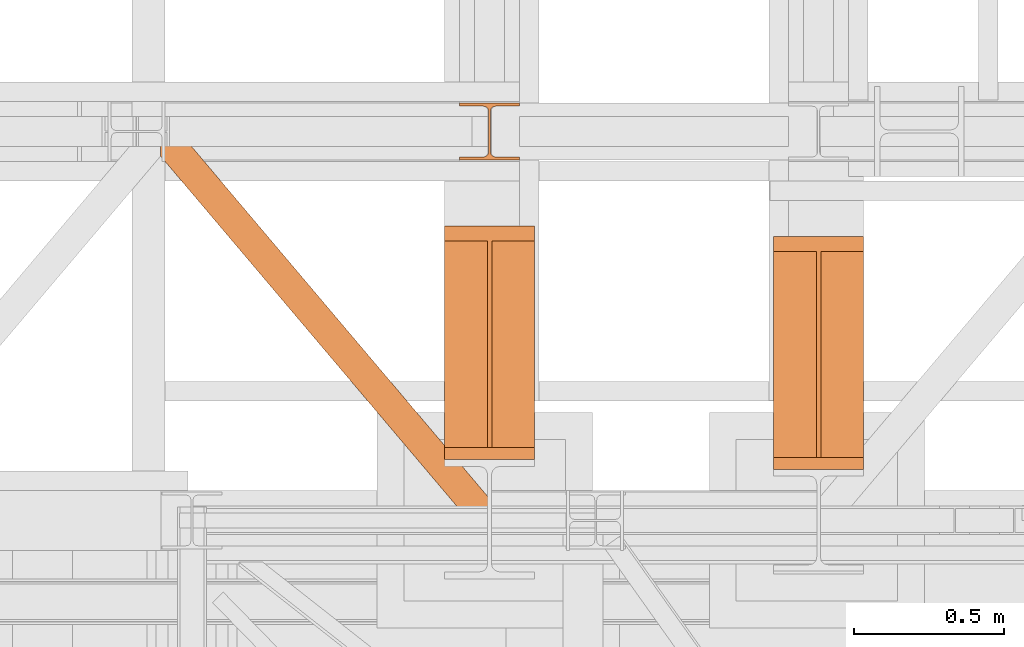
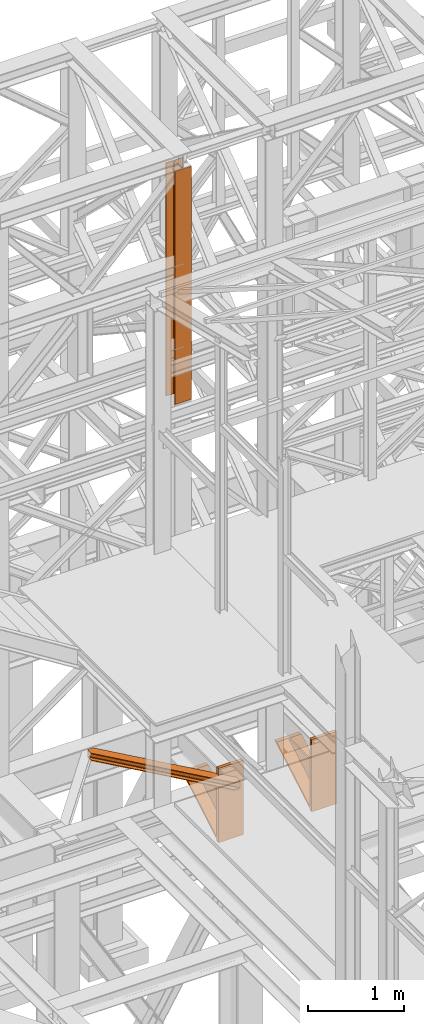
# One storey, part 112 of 208: 4 proxies.
"""IFC2X3 building model written with IfcOpenShell, lengths in millimetres."""

from ifc_helpers import new_model, entity, si_unit, converted_unit, frame, origin, origin_with_axes, place, context, subcontext, project, spatial, faceted_brep, element, save


model = new_model("IFC2X3")

# Units and contexts
model_context = context("Model", 3, precision=1e-05, world=origin())
plan_context = context("Plan", 3, precision=1e-05, world=origin())
body_context = subcontext(model_context, "Body", "Model", "MODEL_VIEW")
ifc_project = project(units=[si_unit("LENGTHUNIT", "METRE", prefix="MILLI"), converted_unit("PLANEANGLEUNIT", "DEGREE", entity("IfcPlaneAngleMeasure", 0.0174532925199433), si_unit("PLANEANGLEUNIT", "RADIAN"), dimensions=[0, 0, 0, 0, 0, 0, 0]), si_unit("AREAUNIT", "SQUARE_METRE"), si_unit("VOLUMEUNIT", "CUBIC_METRE")], contexts=[model_context, plan_context])

# Building, storey
building_placement = place(None, origin())
building = spatial("IfcBuilding", under=ifc_project, at=building_placement, CompositionType="COMPLEX")
storey_placement = place(building_placement, origin_with_axes())
storey = spatial("IfcBuildingStorey", under=building, at=storey_placement, Name="Geschoss", CompositionType="ELEMENT")

# Proxies
proxy_1_placement = place(storey_placement, frame((3143.254962568202, -17092.57439173937, 4367.230005364415), z_axis=(0.0, 0.0, 1.0), x_axis=(1.0, 0.0, 0.0)))
element("IfcBuildingElementProxy", 1, at=proxy_1_placement, inside=storey, context=body_context, shape_type="Brep", body=[
    faceted_brep([(0.01000000000021828, 40.0099999999984, 18.61000000000058), (300.0100000000002, 40.0099999999984, 18.61000000000058), (300.0100000000002, 779.8719999999994, 445.7700000000004), (0.01000000000021828, 779.8719999999994, 445.7700000000004), (0.01000000000021828, 779.8719999999994, 445.7700000000004), (300.0100000000002, 779.8719999999994, 445.7700000000004), (300.0100000000002, 729.8159999999989, 445.7710000000006), (157.5100000000002, 729.8159999999989, 445.7710000000006), (157.5100000000002, 40.0099999999984, 445.7700000000004), (142.5100000000002, 40.0099999999984, 445.7700000000004), (142.5100000000002, 729.8159999999989, 445.7710000000006), (0.01000000000021828, 729.8159999999989, 445.7710000000006), (0.01000000000021828, 729.8159999999989, 445.7710000000006), (142.5100000000002, 729.8159999999989, 445.7710000000006), (142.5100000000002, 40.0099999999984, 47.51000000000022), (0.01000000000021828, 40.0099999999984, 47.51000000000022), (157.5100000000002, 40.0099999999984, 47.51000000000022), (157.5100000000002, 729.8159999999989, 445.7710000000006), (300.0100000000002, 729.8159999999989, 445.7710000000006), (300.0100000000002, 40.0099999999984, 47.51000000000022), (0.01000000000021828, 40.0099999999984, 18.61000000000058), (0.01000000000021828, 779.8719999999994, 445.7700000000004), (0.01000000000021828, 729.8159999999989, 445.7710000000006), (0.01000000000021828, 40.0099999999984, 47.51000000000022), (0.01000000000021828, 40.0099999999984, 917.7700000000004), (0.01000000000021828, 0.00999999999839929, 917.7700000000004), (0.01000000000021828, 0.00999999999839929, 0.01000000000021828), (0.01000000000021828, 40.0099999999984, 0.01000000000021828), (300.0100000000002, 0.00999999999839929, 917.7700000000004), (300.0100000000002, 40.0099999999984, 917.7700000000004), (300.0100000000002, 40.0099999999984, 47.51000000000022), (300.0100000000002, 729.8159999999989, 445.7710000000006), (300.0100000000002, 779.8719999999994, 445.7700000000004), (300.0100000000002, 40.0099999999984, 18.61000000000058), (300.0100000000002, 40.0099999999984, 0.01000000000021828), (300.0100000000002, 0.00999999999839929, 0.01000000000021828), (300.0100000000002, 0.00999999999839929, 917.7700000000004), (0.01000000000021828, 0.00999999999839929, 917.7700000000004), (0.01000000000021828, 40.0099999999984, 917.7700000000004), (300.0100000000002, 40.0099999999984, 917.7700000000004), (300.0100000000002, 40.0099999999984, 917.7700000000004), (0.01000000000021828, 40.0099999999984, 917.7700000000004), (0.01000000000021828, 40.0099999999984, 47.51000000000022), (142.5100000000002, 40.0099999999984, 47.51000000000022), (142.5100000000002, 40.0099999999984, 445.7700000000004), (157.5100000000002, 40.0099999999984, 445.7700000000004), (157.5100000000002, 40.0099999999984, 47.51000000000022), (300.0100000000002, 40.0099999999984, 47.51000000000022), (300.0100000000002, 40.0099999999984, 18.61000000000058), (0.01000000000021828, 40.0099999999984, 18.61000000000058), (0.01000000000021828, 40.0099999999984, 0.01000000000021828), (300.0100000000002, 40.0099999999984, 0.01000000000021828), (300.0100000000002, 40.0099999999984, 0.01000000000021828), (0.01000000000021828, 40.0099999999984, 0.01000000000021828), (0.01000000000021828, 0.00999999999839929, 0.01000000000021828), (300.0100000000002, 0.00999999999839929, 0.01000000000021828), (300.0100000000002, 0.00999999999839929, 0.01000000000021828), (0.01000000000021828, 0.00999999999839929, 0.01000000000021828), (0.01000000000021828, 0.00999999999839929, 917.7700000000004), (300.0100000000002, 0.00999999999839929, 917.7700000000004), (142.5100000000002, 40.0099999999984, 47.51000000000022), (142.5100000000002, 729.8159999999989, 445.7710000000006), (142.5100000000002, 40.0099999999984, 445.7700000000004), (157.5100000000002, 40.0099999999984, 47.51000000000022), (157.5100000000002, 40.0099999999984, 445.7700000000004), (157.5100000000002, 729.8159999999989, 445.7710000000006)], [[[0, 1, 2, 3]], [[4, 5, 6, 7, 8, 9, 10, 11]], [[12, 13, 14, 15]], [[16, 17, 18, 19]], [[20, 21, 22, 23, 24, 25, 26, 27]], [[28, 29, 30, 31, 32, 33, 34, 35]], [[36, 37, 38, 39]], [[40, 41, 42, 43, 44, 45, 46, 47]], [[48, 49, 50, 51]], [[52, 53, 54, 55]], [[56, 57, 58, 59]], [[60, 61, 62]], [[63, 64, 65]]], orient=[[False], [False], [False], [False], [False], [False], [False], [False], [False], [False], [False], [False], [False]]),
])
proxy_2_placement = place(storey_placement, frame((1093.254968528672, -17257.87439359531, 5101.99001616488), z_axis=(0.0, 0.0, 1.0), x_axis=(1.0, 0.0, 0.0)))
element("IfcBuildingElementProxy", 2, at=proxy_2_placement, inside=storey, context=body_context, shape_type="Brep", body=[
    faceted_brep([(65.50764084493926, 1290.610003345228, 8.010001311303313), (65.50764084493926, 1290.610003345228, 0.01000000000112777), (1094.009999947834, 75.10721531453237, 0.01000000000112777), (1094.009999947834, 75.10721531453237, 8.010001311302403), (65.50764084493926, 1290.610003345228, 0.01000000000112777), (0.01000000000271939, 1290.610003345228, 0.01000000000112777), (0.01000000000271939, 1213.20370052848, 0.01000000000112777), (1026.558515831796, 0.00999999999839929, 0.01000000000021828), (1094.009999947834, 0.00999999999839929, 0.01000000000021828), (1094.009999947834, 75.10721531453237, 0.01000000000112777), (0.01000000000271939, 1213.20370052848, 0.01000000000112777), (0.0100000000009004, 1213.203700528482, 8.010001311303313), (1026.558515831796, 0.00999999999839929, 8.010001311303313), (1026.558515831796, 0.00999999999839929, 0.01000000000021828), (0.0100000000009004, 1213.203700528482, 8.010001311303313), (0.01000000000271939, 1268.162175066993, 8.010001311303313), (1073.061840441306, 0.00999999999839929, 8.010001311303313), (1026.558515831796, 0.00999999999839929, 8.010001311303313), (0.01000000000271939, 1268.162175066993, 8.010001311303313), (0.01000000000180989, 1277.776874373867, 9.253033826352294), (1081.197355239431, 0.00999999999839929, 9.253033826352294), (1073.061840441306, 0.00999999999839929, 8.010001311303313), (0.01000000000180989, 1277.776874373867, 9.253033826352294), (0.01000000000180989, 1284.815317712277, 13.79946006298178), (1087.152961141161, 0.00999999999839929, 13.79946006298178), (1081.197355239431, 0.00999999999839929, 9.253033826352294), (0.01000000000180989, 1284.815317712277, 13.79946006298178), (0.01000000000271939, 1286.739687988116, 20.01000141561144), (1088.781274451487, 0.00999999999839929, 20.01000141561144), (1087.152961141161, 0.00999999999839929, 13.79946006298178), (0.01000000000271939, 1286.739687988116, 20.01000141561144), (0.01000000000271939, 1286.739687988116, 76.01000128150099), (1088.781274451487, 0.00999999999839929, 76.01000128150099), (1088.781274451487, 0.00999999999839929, 20.01000141561144), (0.01000000000271939, 1286.739687988116, 76.01000128150099), (0.01000000000180989, 1284.815317712277, 82.2205407714855), (1087.15296114116, 0.00999999999839929, 82.2205407714855), (1088.781274451487, 0.00999999999839929, 76.01000128150099), (0.01000000000180989, 1284.815317712277, 82.2205407714855), (0.01000000000180989, 1277.776874373867, 86.76696700811499), (1081.19735523943, 0.00999999999839929, 86.76696700811499), (1087.15296114116, 0.00999999999839929, 82.2205407714855), (0.01000000000180989, 1277.776874373867, 86.76696700811499), (0.01000000000180989, 1268.162175066993, 88.00999952316397), (1073.061840441305, 0.00999999999839929, 88.00999952316397), (1081.19735523943, 0.00999999999839929, 86.76696700811499), (0.01000000000180989, 1268.162175066993, 88.00999952316397), (0.01000000000271939, 1213.20370052848, 88.00999952316397), (1026.558515831796, 0.00999999999839929, 88.00999952316397), (1073.061840441305, 0.00999999999839929, 88.00999952316397), (0.01000000000271939, 1213.20370052848, 88.00999952316397), (0.009999999999990905, 1213.203700528484, 96.01000083446615), (1026.558515831796, 0.00999999999839929, 96.01000083446615), (1026.558515831796, 0.00999999999839929, 88.00999952316397), (0.009999999999990905, 1213.203700528484, 96.01000083446615), (0.0100000000009004, 1290.610003345228, 96.01000083446615), (65.50764084493835, 1290.610003345228, 96.01000083446615), (1094.009999947834, 75.10721531453237, 96.01000083446615), (1094.009999947834, 0.00999999999839929, 96.01000083446615), (1026.558515831796, 0.00999999999839929, 96.01000083446615), (65.50764084493835, 1290.610003345228, 96.01000083446615), (65.50764084493835, 1290.610003345228, 88.00999952316397), (1094.009999947834, 75.10721531453237, 88.00999952316397), (1094.009999947834, 75.10721531453237, 96.01000083446615), (65.50764084493835, 1290.610003345228, 88.00999952316397), (19.0043162354275, 1290.610003345228, 88.00999952316397), (1094.009999947834, 20.14874077602144, 88.00999952316397), (1094.009999947834, 75.10721531453237, 88.00999952316397), (19.0043162354275, 1290.610003345228, 88.00999952316397), (10.86880143730173, 1290.610003345228, 86.76696700811499), (1094.009999947834, 10.53404146914545, 86.76696700811499), (1094.009999947834, 20.14874077602144, 88.00999952316397), (10.86880143730173, 1290.610003345228, 86.76696700811499), (4.913195535572186, 1290.610003345228, 82.2205407714855), (1094.009999947834, 3.495598130739381, 82.2205407714855), (1094.009999947834, 10.53404146914545, 86.76696700811499), (4.913195535572186, 1290.610003345228, 82.2205407714855), (3.284882225245156, 1290.610003345228, 76.01000128150099), (1094.009999947833, 1.571227854896279, 76.01000128150099), (1094.009999947834, 3.495598130739381, 82.2205407714855), (3.284882225245156, 1290.610003345228, 76.01000128150099), (3.284882225246065, 1290.610003345228, 20.01000141561144), (1094.009999947834, 1.571227854896279, 20.01000141561144), (1094.009999947833, 1.571227854896279, 76.01000128150099), (3.284882225246065, 1290.610003345228, 20.01000141561144), (4.913195535572186, 1290.610003345228, 13.79946006298178), (1094.009999947834, 3.495598130735743, 13.79946006298178), (1094.009999947834, 1.571227854896279, 20.01000141561144), (4.913195535572186, 1290.610003345228, 13.79946006298178), (10.86880143730264, 1290.610003345228, 9.253033826352294), (1094.009999947834, 10.53404146914545, 9.253033826352294), (1094.009999947834, 3.495598130735743, 13.79946006298178), (10.86880143730264, 1290.610003345228, 9.253033826352294), (19.00431623542931, 1290.610003345228, 8.010001311303313), (1094.009999947834, 20.14874077602144, 8.010001311303313), (1094.009999947834, 10.53404146914545, 9.253033826352294), (19.00431623542931, 1290.610003345228, 8.010001311303313), (65.50764084493926, 1290.610003345228, 8.010001311303313), (1094.009999947834, 75.10721531453237, 8.010001311302403), (1094.009999947834, 20.14874077602144, 8.010001311303313), (0.01000000000271939, 1213.20370052848, 0.01000000000112777), (0.01000000000271939, 1290.610003345228, 0.01000000000112777), (0.0100000000009004, 1290.610003345228, 96.01000083446615), (0.009999999999990905, 1213.203700528484, 96.01000083446615), (0.01000000000271939, 1213.20370052848, 88.00999952316397), (0.01000000000180989, 1268.162175066993, 88.00999952316397), (0.01000000000180989, 1277.776874373867, 86.76696700811499), (0.01000000000180989, 1284.815317712277, 82.2205407714855), (0.01000000000271939, 1286.739687988116, 76.01000128150099), (0.01000000000271939, 1286.739687988116, 20.01000141561144), (0.01000000000180989, 1284.815317712277, 13.79946006298178), (0.01000000000180989, 1277.776874373867, 9.253033826352294), (0.01000000000271939, 1268.162175066993, 8.010001311303313), (0.0100000000009004, 1213.203700528482, 8.010001311303313), (0.0100000000009004, 1290.610003345228, 96.01000083446615), (0.01000000000271939, 1290.610003345228, 0.01000000000112777), (65.50764084493926, 1290.610003345228, 0.01000000000112777), (65.50764084493926, 1290.610003345228, 8.010001311303313), (19.00431623542931, 1290.610003345228, 8.010001311303313), (10.86880143730264, 1290.610003345228, 9.253033826352294), (4.913195535572186, 1290.610003345228, 13.79946006298178), (3.284882225246065, 1290.610003345228, 20.01000141561144), (3.284882225245156, 1290.610003345228, 76.01000128150099), (4.913195535572186, 1290.610003345228, 82.2205407714855), (10.86880143730173, 1290.610003345228, 86.76696700811499), (19.0043162354275, 1290.610003345228, 88.00999952316397), (65.50764084493835, 1290.610003345228, 88.00999952316397), (65.50764084493835, 1290.610003345228, 96.01000083446615), (1094.009999947834, 75.10721531453237, 8.010001311302403), (1094.009999947834, 75.10721531453237, 0.01000000000112777), (1094.009999947834, 0.00999999999839929, 0.01000000000021828), (1094.009999947834, 0.00999999999839929, 96.01000083446615), (1094.009999947834, 75.10721531453237, 96.01000083446615), (1094.009999947834, 75.10721531453237, 88.00999952316397), (1094.009999947834, 20.14874077602144, 88.00999952316397), (1094.009999947834, 10.53404146914545, 86.76696700811499), (1094.009999947834, 3.495598130739381, 82.2205407714855), (1094.009999947833, 1.571227854896279, 76.01000128150099), (1094.009999947834, 1.571227854896279, 20.01000141561144), (1094.009999947834, 3.495598130735743, 13.79946006298178), (1094.009999947834, 10.53404146914545, 9.253033826352294), (1094.009999947834, 20.14874077602144, 8.010001311303313), (1094.009999947834, 0.00999999999839929, 0.01000000000021828), (1026.558515831796, 0.00999999999839929, 0.01000000000021828), (1026.558515831796, 0.00999999999839929, 8.010001311303313), (1073.061840441306, 0.00999999999839929, 8.010001311303313), (1081.197355239431, 0.00999999999839929, 9.253033826352294), (1087.152961141161, 0.00999999999839929, 13.79946006298178), (1088.781274451487, 0.00999999999839929, 20.01000141561144), (1088.781274451487, 0.00999999999839929, 76.01000128150099), (1087.15296114116, 0.00999999999839929, 82.2205407714855), (1081.19735523943, 0.00999999999839929, 86.76696700811499), (1073.061840441305, 0.00999999999839929, 88.00999952316397), (1026.558515831796, 0.00999999999839929, 88.00999952316397), (1026.558515831796, 0.00999999999839929, 96.01000083446615), (1094.009999947834, 0.00999999999839929, 96.01000083446615)], [[[0, 1, 2, 3]], [[4, 5, 6, 7, 8, 9]], [[10, 11, 12, 13]], [[14, 15, 16, 17]], [[18, 19, 20, 21]], [[22, 23, 24, 25]], [[26, 27, 28, 29]], [[30, 31, 32, 33]], [[34, 35, 36, 37]], [[38, 39, 40, 41]], [[42, 43, 44, 45]], [[46, 47, 48, 49]], [[50, 51, 52, 53]], [[54, 55, 56, 57, 58, 59]], [[60, 61, 62, 63]], [[64, 65, 66, 67]], [[68, 69, 70, 71]], [[72, 73, 74, 75]], [[76, 77, 78, 79]], [[80, 81, 82, 83]], [[84, 85, 86, 87]], [[88, 89, 90, 91]], [[92, 93, 94, 95]], [[96, 97, 98, 99]], [[100, 101, 102, 103, 104, 105, 106, 107, 108, 109, 110, 111, 112, 113]], [[114, 115, 116, 117, 118, 119, 120, 121, 122, 123, 124, 125, 126, 127]], [[128, 129, 130, 131, 132, 133, 134, 135, 136, 137, 138, 139, 140, 141]], [[142, 143, 144, 145, 146, 147, 148, 149, 150, 151, 152, 153, 154, 155]]], orient=[[False], [False], [False], [False], [False], [False], [False], [False], [False], [False], [False], [False], [False], [False], [False], [False], [False], [False], [False], [False], [False], [False], [False], [False], [False], [False], [False], [False]]),
])
proxy_3_placement = place(storey_placement, frame((2043.254968528667, -17058.57439531565, 4339.230005364416), z_axis=(0.0, 0.0, 1.0), x_axis=(1.0, 0.0, 0.0)))
element("IfcBuildingElementProxy", 3, at=proxy_3_placement, inside=storey, context=body_context, shape_type="Brep", body=[
    faceted_brep([(0.01000000000021828, 40.0099999999984, 18.61000000000058), (300.0100000000002, 40.0099999999984, 18.61000000000058), (300.0099999999998, 779.8719999999994, 445.7700000000004), (0.009999999999990905, 779.8719999999994, 445.7700000000004), (0.009999999999990905, 779.8719999999994, 445.7700000000004), (300.0099999999998, 779.8719999999994, 445.7700000000004), (300.0099999999998, 729.8160000000007, 445.7710000000006), (157.5099999999998, 729.8160000000007, 445.7710000000006), (142.5099999999998, 729.8160000000007, 445.7710000000006), (0.009999999999990905, 729.8160000000007, 445.7710000000006), (0.009999999999990905, 729.8160000000007, 445.7710000000006), (142.5099999999998, 729.8160000000007, 445.7710000000006), (142.5100000000002, 40.0099999999984, 47.51000000000022), (0.01000000000021828, 40.0099999999984, 47.51000000000022), (157.5100000000002, 40.0099999999984, 47.51000000000022), (157.5099999999998, 729.8160000000007, 445.7710000000006), (300.0099999999998, 729.8160000000007, 445.7710000000006), (300.0100000000002, 40.0099999999984, 47.51000000000022), (0.01000000000021828, 40.0099999999984, 18.61000000000058), (0.009999999999990905, 779.8719999999994, 445.7700000000004), (0.009999999999990905, 729.8160000000007, 445.7710000000006), (0.01000000000021828, 40.0099999999984, 47.51000000000022), (0.01000000000021828, 40.0099999999984, 945.7700000000004), (0.01000000000021828, 0.00999999999839929, 945.7700000000004), (0.01000000000021828, 0.00999999999839929, 0.01000000000021828), (0.01000000000021828, 40.0099999999984, 0.01000000000021828), (300.0100000000002, 0.01000000000203727, 945.7700000000004), (300.0100000000002, 40.0099999999984, 945.7700000000004), (300.0100000000002, 40.0099999999984, 47.51000000000022), (300.0099999999998, 729.8160000000007, 445.7710000000006), (300.0099999999998, 779.8719999999994, 445.7700000000004), (300.0100000000002, 40.0099999999984, 18.61000000000058), (300.0100000000002, 40.0099999999984, 0.01000000000021828), (300.0100000000002, 0.00999999999839929, 0.01000000000021828), (300.0100000000002, 0.01000000000203727, 945.7700000000004), (0.01000000000021828, 0.00999999999839929, 945.7700000000004), (0.01000000000021828, 40.0099999999984, 945.7700000000004), (300.0100000000002, 40.0099999999984, 945.7700000000004), (300.0100000000002, 40.0099999999984, 945.7700000000004), (0.01000000000021828, 40.0099999999984, 945.7700000000004), (0.01000000000021828, 40.0099999999984, 47.51000000000022), (142.5100000000002, 40.0099999999984, 47.51000000000022), (142.5100000000002, 40.0099999999984, 445.7700000000004), (157.5100000000002, 40.0099999999984, 445.7700000000004), (157.5100000000002, 40.0099999999984, 47.51000000000022), (300.0100000000002, 40.0099999999984, 47.51000000000022), (300.0100000000002, 40.0099999999984, 18.61000000000058), (0.01000000000021828, 40.0099999999984, 18.61000000000058), (0.01000000000021828, 40.0099999999984, 0.01000000000021828), (300.0100000000002, 40.0099999999984, 0.01000000000021828), (300.0100000000002, 40.0099999999984, 0.01000000000021828), (0.01000000000021828, 40.0099999999984, 0.01000000000021828), (0.01000000000021828, 0.00999999999839929, 0.01000000000021828), (300.0100000000002, 0.00999999999839929, 0.01000000000021828), (300.0100000000002, 0.00999999999839929, 0.01000000000021828), (0.01000000000021828, 0.00999999999839929, 0.01000000000021828), (0.01000000000021828, 0.00999999999839929, 945.7700000000004), (300.0100000000002, 0.01000000000203727, 945.7700000000004), (142.5099999999998, 729.8160000000007, 445.7710000000006), (157.5099999999998, 729.8160000000007, 445.7710000000006), (157.5100000000002, 40.0099999999984, 445.7700000000004), (142.5100000000002, 40.0099999999984, 445.7700000000004), (142.5100000000002, 40.0099999999984, 47.51000000000022), (142.5099999999998, 729.8160000000007, 445.7710000000006), (142.5100000000002, 40.0099999999984, 445.7700000000004), (157.5100000000002, 40.0099999999984, 47.51000000000022), (157.5100000000002, 40.0099999999984, 445.7700000000004), (157.5099999999998, 729.8160000000007, 445.7710000000006)], [[[0, 1, 2, 3]], [[4, 5, 6, 7, 8, 9]], [[10, 11, 12, 13]], [[14, 15, 16, 17]], [[18, 19, 20, 21, 22, 23, 24, 25]], [[26, 27, 28, 29, 30, 31, 32, 33]], [[34, 35, 36, 37]], [[38, 39, 40, 41, 42, 43, 44, 45]], [[46, 47, 48, 49]], [[50, 51, 52, 53]], [[54, 55, 56, 57]], [[58, 59, 60, 61]], [[62, 63, 64]], [[65, 66, 67]]], orient=[[False], [False], [False], [False], [False], [False], [False], [False], [False], [False], [False], [False], [False], [False]]),
])
proxy_4_placement = place(storey_placement, frame((2093.254967038548, -16057.57439657638, 9284.990005364414), z_axis=(0.0, 0.0, 1.0), x_axis=(1.0, 0.0, 0.0)))
element("IfcBuildingElementProxy", 4, at=proxy_4_placement, inside=storey, context=body_context, shape_type="Brep", body=[
    faceted_brep([(0.01000000000021828, 190.0100125169756, 2965.010053329395), (200.0100029802325, 190.0100125169756, 2965.010053329395), (200.0100029802325, 180.0100146031382, 2965.010053329395), (121.2600035762789, 180.0100071525576, 2965.010053329395), (111.9441915473344, 178.1454621052744, 2965.010053329395), (105.1245498640838, 171.3258190250399, 2965.010053329395), (103.2600015571716, 162.010007927418, 2965.010053329395), (103.2600015571716, 28.00999713897727, 2965.010053329395), (105.1245498640838, 18.69418604135535, 2965.010053329395), (111.9441915473344, 11.87454296112082, 2965.010053329395), (121.2600035762789, 10.00999791383765, 2965.010053329395), (200.0100029802325, 10.00999791383765, 2965.010053329395), (200.0100029802325, 0.01000000000021828, 2965.010053329395), (0.01000000000021828, 0.01000000000021828, 2965.010053329395), (0.01000000000021828, 10.00999791383765, 2965.010053329395), (78.75999940395377, 10.00999791383765, 2965.010053329395), (88.07581143289826, 11.87454296112082, 2965.010053329395), (94.89545311614893, 18.69418604135535, 2965.010053329395), (96.76000142306111, 28.00999713897727, 2965.010053329395), (96.76000142306111, 162.010007927418, 2965.010053329395), (94.89545311614893, 171.3258190250399, 2965.010053329395), (88.07581143289826, 178.1454621052744, 2965.010053329395), (78.75999940395377, 180.0100071525576, 2965.010053329395), (0.01000000000021828, 180.0100146031382, 2965.010053329395), (200.0100029802325, 190.0100125169756, 2965.010053329395), (0.01000000000021828, 190.0100125169756, 2965.010053329395), (0.01000000000112777, 190.0100125169756, 0.01000000000021828), (200.0100029802334, 190.0100125169756, 0.01000000000021828), (200.0100029802325, 180.0100146031382, 2965.010053329395), (200.0100029802325, 190.0100125169756, 2965.010053329395), (200.0100029802334, 190.0100125169756, 0.01000000000021828), (200.0100029802334, 180.0100146031382, 0.01000000000021828), (121.2600035762789, 180.0100071525576, 2965.010053329395), (200.0100029802325, 180.0100146031382, 2965.010053329395), (200.0100029802334, 180.0100146031382, 0.01000000000021828), (121.2600035762798, 180.0100071525576, 0.01000000000021828), (111.9441915473344, 178.1454621052744, 2965.010053329395), (121.2600035762789, 180.0100071525576, 2965.010053329395), (121.2600035762798, 180.0100071525576, 0.01000000000021828), (111.9441915473353, 178.1454621052744, 0.01000000000021828), (105.1245498640838, 171.3258190250399, 2965.010053329395), (111.9441915473344, 178.1454621052744, 2965.010053329395), (111.9441915473353, 178.1454621052744, 0.01000000000021828), (105.1245498640847, 171.3258190250399, 0.01000000000021828), (103.2600015571716, 162.010007927418, 2965.010053329395), (105.1245498640838, 171.3258190250399, 2965.010053329395), (105.1245498640847, 171.3258190250399, 0.01000000000021828), (103.2600015571725, 162.010007927418, 0.01000000000021828), (103.2600015571716, 28.00999713897727, 2965.010053329395), (103.2600015571716, 162.010007927418, 2965.010053329395), (103.2600015571725, 162.010007927418, 0.01000000000021828), (103.2600015571725, 28.00999713897727, 0.01000000000021828), (105.1245498640838, 18.69418604135535, 2965.010053329395), (103.2600015571716, 28.00999713897727, 2965.010053329395), (103.2600015571725, 28.00999713897727, 0.01000000000021828), (105.1245498640847, 18.69418604135535, 0.01000000000021828), (111.9441915473344, 11.87454296112082, 2965.010053329395), (105.1245498640838, 18.69418604135535, 2965.010053329395), (105.1245498640847, 18.69418604135535, 0.01000000000021828), (111.9441915473353, 11.87454296112082, 0.01000000000021828), (121.2600035762789, 10.00999791383765, 2965.010053329395), (111.9441915473344, 11.87454296112082, 2965.010053329395), (111.9441915473353, 11.87454296112082, 0.01000000000021828), (121.2600035762798, 10.00999791383765, 0.01000000000021828), (200.0100029802325, 10.00999791383765, 2965.010053329395), (121.2600035762789, 10.00999791383765, 2965.010053329395), (121.2600035762798, 10.00999791383765, 0.01000000000021828), (200.0100029802334, 10.00999791383765, 0.01000000000021828), (200.0100029802325, 0.01000000000021828, 2965.010053329395), (200.0100029802325, 10.00999791383765, 2965.010053329395), (200.0100029802334, 10.00999791383765, 0.01000000000021828), (200.0100029802334, 0.01000000000021828, 0.01000000000021828), (0.01000000000021828, 0.01000000000021828, 2965.010053329395), (200.0100029802325, 0.01000000000021828, 2965.010053329395), (200.0100029802334, 0.01000000000021828, 0.01000000000021828), (0.01000000000112777, 0.01000000000021828, 0.01000000000021828), (0.01000000000021828, 10.00999791383765, 2965.010053329395), (0.01000000000021828, 0.01000000000021828, 2965.010053329395), (0.01000000000112777, 0.01000000000021828, 0.01000000000021828), (0.01000000000112777, 10.00999791383765, 0.01000000000021828), (78.75999940395377, 10.00999791383765, 2965.010053329395), (0.01000000000021828, 10.00999791383765, 2965.010053329395), (0.01000000000112777, 10.00999791383765, 0.01000000000021828), (78.75999940395468, 10.00999791383765, 0.01000000000021828), (88.07581143289826, 11.87454296112082, 2965.010053329395), (78.75999940395377, 10.00999791383765, 2965.010053329395), (78.75999940395468, 10.00999791383765, 0.01000000000021828), (88.07581143289917, 11.87454296112082, 0.01000000000021828), (94.89545311614893, 18.69418604135535, 2965.010053329395), (88.07581143289826, 11.87454296112082, 2965.010053329395), (88.07581143289917, 11.87454296112082, 0.01000000000021828), (94.89545311614984, 18.69418604135535, 0.01000000000021828), (96.76000142306111, 28.00999713897727, 2965.010053329395), (94.89545311614893, 18.69418604135535, 2965.010053329395), (94.89545311614984, 18.69418604135535, 0.01000000000021828), (96.76000142306202, 28.00999713897727, 0.01000000000021828), (96.76000142306111, 162.010007927418, 2965.010053329395), (96.76000142306111, 28.00999713897727, 2965.010053329395), (96.76000142306202, 28.00999713897727, 0.01000000000021828), (96.76000142306202, 162.010007927418, 0.01000000000021828), (94.89545311614893, 171.3258190250399, 2965.010053329395), (96.76000142306111, 162.010007927418, 2965.010053329395), (96.76000142306202, 162.010007927418, 0.01000000000021828), (94.89545311614984, 171.3258190250399, 0.01000000000021828), (88.07581143289826, 178.1454621052744, 2965.010053329395), (94.89545311614893, 171.3258190250399, 2965.010053329395), (94.89545311614984, 171.3258190250399, 0.01000000000021828), (88.07581143289917, 178.1454621052744, 0.01000000000021828), (78.75999940395377, 180.0100071525576, 2965.010053329395), (88.07581143289826, 178.1454621052744, 2965.010053329395), (88.07581143289917, 178.1454621052744, 0.01000000000021828), (78.75999940395468, 180.0100071525576, 0.01000000000021828), (0.01000000000021828, 180.0100146031382, 2965.010053329395), (78.75999940395377, 180.0100071525576, 2965.010053329395), (78.75999940395468, 180.0100071525576, 0.01000000000021828), (0.01000000000112777, 180.0100146031382, 0.01000000000021828), (0.01000000000021828, 190.0100125169756, 2965.010053329395), (0.01000000000021828, 180.0100146031382, 2965.010053329395), (0.01000000000112777, 180.0100146031382, 0.01000000000021828), (0.01000000000112777, 190.0100125169756, 0.01000000000021828), (0.01000000000112777, 190.0100125169756, 0.01000000000021828), (0.01000000000112777, 180.0100146031382, 0.01000000000021828), (78.75999940395468, 180.0100071525576, 0.01000000000021828), (88.07581143289917, 178.1454621052744, 0.01000000000021828), (94.89545311614984, 171.3258190250399, 0.01000000000021828), (96.76000142306202, 162.010007927418, 0.01000000000021828), (96.76000142306202, 28.00999713897727, 0.01000000000021828), (94.89545311614984, 18.69418604135535, 0.01000000000021828), (88.07581143289917, 11.87454296112082, 0.01000000000021828), (78.75999940395468, 10.00999791383765, 0.01000000000021828), (0.01000000000112777, 10.00999791383765, 0.01000000000021828), (0.01000000000112777, 0.01000000000021828, 0.01000000000021828), (200.0100029802334, 0.01000000000021828, 0.01000000000021828), (200.0100029802334, 10.00999791383765, 0.01000000000021828), (121.2600035762798, 10.00999791383765, 0.01000000000021828), (111.9441915473353, 11.87454296112082, 0.01000000000021828), (105.1245498640847, 18.69418604135535, 0.01000000000021828), (103.2600015571725, 28.00999713897727, 0.01000000000021828), (103.2600015571725, 162.010007927418, 0.01000000000021828), (105.1245498640847, 171.3258190250399, 0.01000000000021828), (111.9441915473353, 178.1454621052744, 0.01000000000021828), (121.2600035762798, 180.0100071525576, 0.01000000000021828), (200.0100029802334, 180.0100146031382, 0.01000000000021828), (200.0100029802334, 190.0100125169756, 0.01000000000021828)], [[[0, 1, 2, 3, 4, 5, 6, 7, 8, 9, 10, 11, 12, 13, 14, 15, 16, 17, 18, 19, 20, 21, 22, 23]], [[24, 25, 26, 27]], [[28, 29, 30, 31]], [[32, 33, 34, 35]], [[36, 37, 38, 39]], [[40, 41, 42, 43]], [[44, 45, 46, 47]], [[48, 49, 50, 51]], [[52, 53, 54, 55]], [[56, 57, 58, 59]], [[60, 61, 62, 63]], [[64, 65, 66, 67]], [[68, 69, 70, 71]], [[72, 73, 74, 75]], [[76, 77, 78, 79]], [[80, 81, 82, 83]], [[84, 85, 86, 87]], [[88, 89, 90, 91]], [[92, 93, 94, 95]], [[96, 97, 98, 99]], [[100, 101, 102, 103]], [[104, 105, 106, 107]], [[108, 109, 110, 111]], [[112, 113, 114, 115]], [[116, 117, 118, 119]], [[120, 121, 122, 123, 124, 125, 126, 127, 128, 129, 130, 131, 132, 133, 134, 135, 136, 137, 138, 139, 140, 141, 142, 143]]], orient=[[False], [False], [False], [False], [False], [False], [False], [False], [False], [False], [False], [False], [False], [False], [False], [False], [False], [False], [False], [False], [False], [False], [False], [False], [False], [False]]),
])

save(model, "model.ifc")
